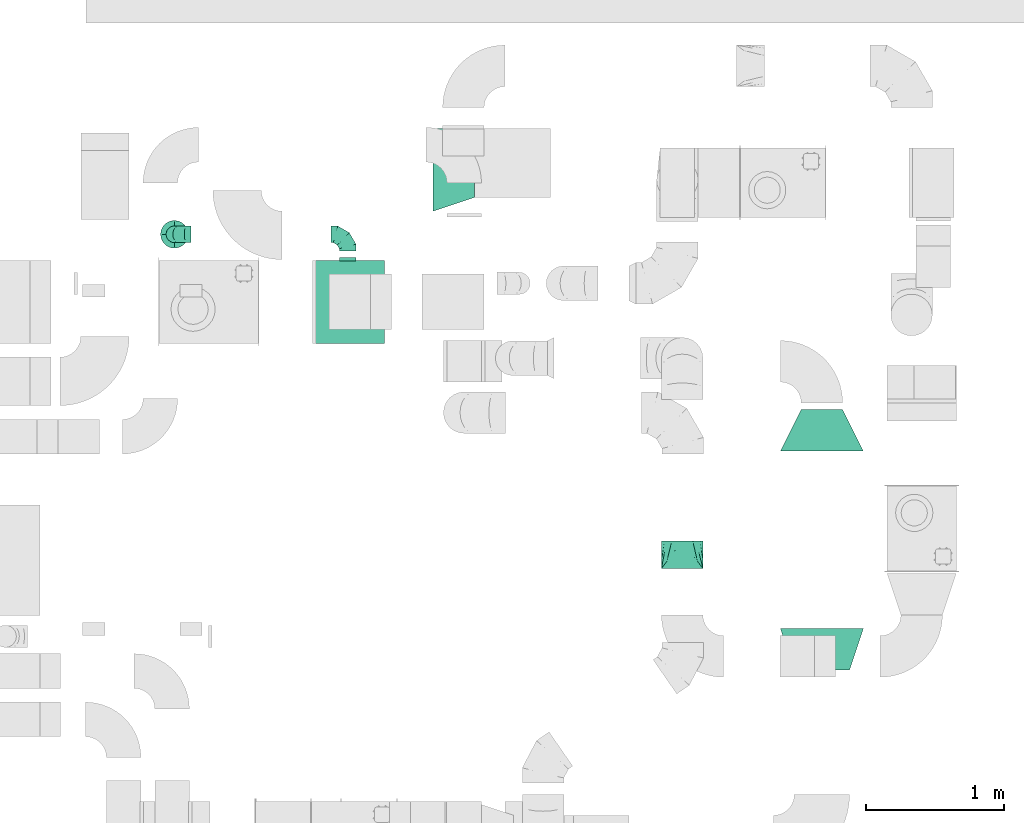
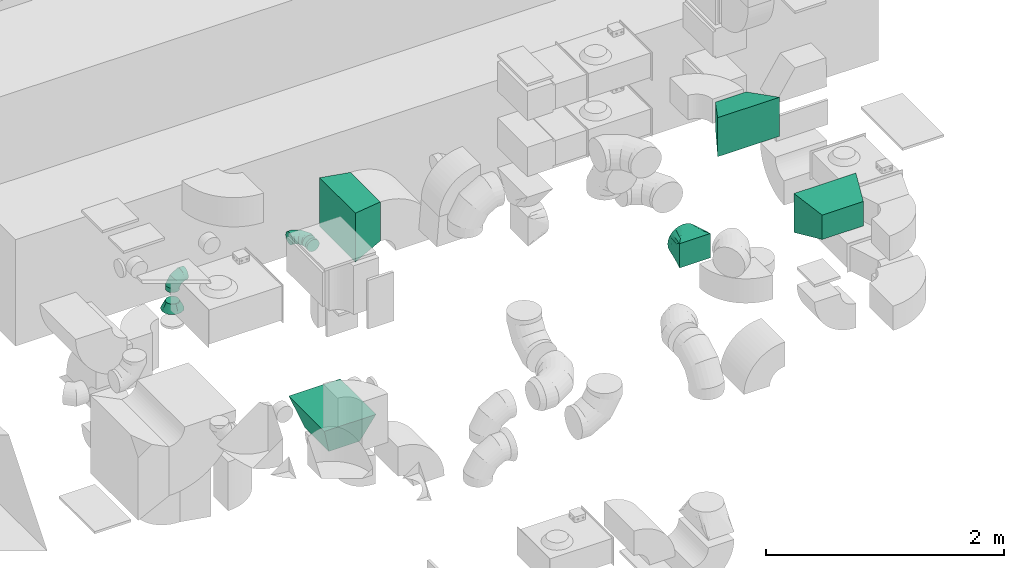
# One storey, part 51 of 59: 9 flow fittings.
"""IFC2X3 building model written with IfcOpenShell, lengths in millimetres."""

from ifc_helpers import new_model, entity, si_unit, converted_unit, derived_unit, direction, frame, origin, place, context, subcontext, project, spatial, faceted_brep, source, transform, mapped, material, type_object, type_shapes, element, save


model = new_model("IFC2X3")

# Units and contexts
model_context = context("Model", 3, precision=0.01, world=origin(), true_north=direction((6.12303176911189e-17, 1.0)))
body_context = subcontext(model_context, "Body", "Model", "MODEL_VIEW")
ifc_project = project(units=[si_unit("LENGTHUNIT", "METRE", prefix="MILLI"), si_unit("AREAUNIT", "SQUARE_METRE"), si_unit("VOLUMEUNIT", "CUBIC_METRE"), converted_unit("PLANEANGLEUNIT", "DEGREE", entity("IfcRatioMeasure", 0.0174532925199433), si_unit("PLANEANGLEUNIT", "RADIAN"), dimensions=[0, 0, 0, 0, 0, 0, 0]), si_unit("MASSUNIT", "GRAM", prefix="KILO"), derived_unit("MASSDENSITYUNIT", [(si_unit("MASSUNIT", "GRAM", prefix="KILO"), 1), (si_unit("LENGTHUNIT", "METRE"), -3)]), derived_unit("MOMENTOFINERTIAUNIT", [(si_unit("LENGTHUNIT", "METRE"), 4)]), si_unit("TIMEUNIT", "SECOND"), si_unit("FREQUENCYUNIT", "HERTZ"), si_unit("THERMODYNAMICTEMPERATUREUNIT", "DEGREE_CELSIUS"), derived_unit("THERMALTRANSMITTANCEUNIT", [(si_unit("MASSUNIT", "GRAM", prefix="KILO"), 1), (si_unit("THERMODYNAMICTEMPERATUREUNIT", "KELVIN"), -1), (si_unit("TIMEUNIT", "SECOND"), -3)]), derived_unit("VOLUMETRICFLOWRATEUNIT", [(si_unit("LENGTHUNIT", "METRE"), 3), (si_unit("TIMEUNIT", "SECOND"), -1)]), derived_unit("MASSFLOWRATEUNIT", [(si_unit("MASSUNIT", "GRAM", prefix="KILO"), 1), (si_unit("TIMEUNIT", "SECOND"), -1)]), derived_unit("ROTATIONALFREQUENCYUNIT", [(si_unit("TIMEUNIT", "SECOND"), -1)]), si_unit("ELECTRICCURRENTUNIT", "AMPERE"), si_unit("ELECTRICVOLTAGEUNIT", "VOLT"), si_unit("POWERUNIT", "WATT"), si_unit("FORCEUNIT", "NEWTON", prefix="KILO"), si_unit("ILLUMINANCEUNIT", "LUX"), si_unit("LUMINOUSFLUXUNIT", "LUMEN"), si_unit("LUMINOUSINTENSITYUNIT", "CANDELA"), derived_unit("USERDEFINED", [(si_unit("MASSUNIT", "GRAM", prefix="KILO"), -1), (si_unit("LENGTHUNIT", "METRE"), -2), (si_unit("TIMEUNIT", "SECOND"), 3), (si_unit("LUMINOUSFLUXUNIT", "LUMEN"), 1)]), derived_unit("LINEARVELOCITYUNIT", [(si_unit("LENGTHUNIT", "METRE"), 1), (si_unit("TIMEUNIT", "SECOND"), -1)]), si_unit("PRESSUREUNIT", "PASCAL"), derived_unit("USERDEFINED", [(si_unit("LENGTHUNIT", "METRE"), -2), (si_unit("MASSUNIT", "GRAM", prefix="KILO"), 1), (si_unit("TIMEUNIT", "SECOND"), -2)]), derived_unit("LINEARFORCEUNIT", [(si_unit("MASSUNIT", "GRAM", prefix="KILO"), 1), (si_unit("LENGTHUNIT", "METRE"), 1), (si_unit("TIMEUNIT", "SECOND"), -2), (si_unit("LENGTHUNIT", "METRE"), -1)]), derived_unit("PLANARFORCEUNIT", [(si_unit("MASSUNIT", "GRAM", prefix="KILO"), 1), (si_unit("LENGTHUNIT", "METRE"), 1), (si_unit("TIMEUNIT", "SECOND"), -2), (si_unit("LENGTHUNIT", "METRE"), -2)])], contexts=[model_context])

# Site, building, storey
site_placement = place(None, origin())
site = spatial("IfcSite", under=ifc_project, at=site_placement, CompositionType="ELEMENT")
building_placement = place(site_placement, origin())
building = spatial("IfcBuilding", under=site, at=building_placement, CompositionType="ELEMENT")
storey_placement = place(building_placement, frame((0.0, 0.0, 28200.0)))
storey = spatial("IfcBuildingStorey", under=building, at=storey_placement, CompositionType="ELEMENT", Elevation=28200.0)

# Flow fittings
ifc_material = material()
duct_fitting_type_1 = type_object("IfcDuctFittingType", PredefinedType="NOTDEFINED", material=ifc_material)
shared_shape_1 = source(origin(), body_context, "Body", "Brep", [
    faceted_brep([(300.0, -150.0, 125.0), (300.0, -150.0, -125.0), (300.0, 150.0, -125.0), (300.0, 150.0, 125.0), (0.0, -300.0, 200.0), (0.0, 300.0, 200.0), (0.0, 300.0, -200.0), (0.0, -300.0, -200.0)], [[[0, 1, 2, 3]], [[4, 5, 6, 7]], [[4, 7, 1, 0]], [[7, 6, 2, 1]], [[6, 5, 3, 2]], [[5, 4, 0, 3]]]),
])
type_shapes(duct_fitting_type_1, [shared_shape_1])
flow_fitting_1_placement = place(storey_placement, frame((33725.03, 10965.73, 3500.0), z_axis=(0.0, 0.0, 1.0), x_axis=(0.0, 1.0, 0.0)))
element("IfcFlowFitting", 1, at=flow_fitting_1_placement, inside=storey, type_object=duct_fitting_type_1, material=ifc_material, context=body_context, shape_type="MappedRepresentation", body=[
    mapped(shared_shape_1, transform((0.0, 0.0, 0.0), scale=1.0)),
])
duct_fitting_type_2 = type_object("IfcDuctFittingType", PredefinedType="NOTDEFINED", material=ifc_material)
shared_shape_2 = source(origin(), body_context, "Body", "Brep", [
    faceted_brep([(200.0, 75.0, 129.9), (200.0, 56.91, 137.4), (200.0, 38.82, 144.89), (200.0, 26.6, 146.5), (200.0, 14.38, 148.11), (200.0, 0.0, 150.0), (200.0, -14.38, 148.11), (200.0, -26.6, 146.5), (200.0, -38.82, 144.89), (200.0, -56.91, 137.4), (200.0, -75.0, 129.9), (200.0, -90.53, 117.98), (200.0, -106.07, 106.07), (200.0, -117.98, 90.53), (200.0, -129.9, 75.0), (200.0, -137.4, 56.91), (200.0, -144.89, 38.82), (200.0, -146.5, 26.6), (200.0, -148.11, 14.38), (200.0, -150.0, 0.0), (200.0, -148.11, -14.38), (200.0, -146.5, -26.6), (200.0, -144.89, -38.82), (200.0, -137.4, -56.91), (200.0, -129.9, -75.0), (200.0, -117.98, -90.53), (200.0, -106.07, -106.07), (200.0, -90.53, -117.98), (200.0, -75.0, -129.9), (200.0, -56.91, -137.4), (200.0, -38.82, -144.89), (200.0, -26.6, -146.5), (200.0, -14.38, -148.11), (200.0, 0.0, -150.0), (200.0, 14.38, -148.11), (200.0, 26.6, -146.5), (200.0, 38.82, -144.89), (200.0, 56.91, -137.4), (200.0, 75.0, -129.9), (200.0, 90.53, -117.98), (200.0, 106.07, -106.07), (200.0, 117.98, -90.53), (200.0, 129.9, -75.0), (200.0, 137.4, -56.91), (200.0, 144.89, -38.82), (200.0, 146.5, -26.6), (200.0, 148.11, -14.38), (200.0, 150.0, 0.0), (200.0, 148.11, 14.38), (200.0, 146.5, 26.6), (200.0, 144.89, 38.82), (200.0, 137.4, 56.91), (200.0, 129.9, 75.0), (200.0, 117.98, 90.53), (200.0, 106.07, 106.07), (200.0, 90.53, 117.98), (0.0, -150.0, 125.0), (0.0, 150.0, 125.0), (0.0, 150.0, -125.0), (0.0, -150.0, -125.0), (128.09, -53.94, 141.01), (104.11, -71.91, 138.01), (78.09, -91.44, 134.76), (100.0, -124.73, 118.65), (26.03, -130.48, 128.25), (52.06, -150.0, 92.46), (26.03, -150.0, 108.73), (78.09, -150.0, 76.2), (104.11, -150.0, 59.93), (128.09, -150.0, 44.95), (176.03, -17.98, 147.0), (152.06, -35.96, 144.01), (152.06, -150.0, 29.96), (176.03, -150.0, 14.98), (52.06, -110.96, 131.51), (26.03, -150.0, -108.73), (52.06, -150.0, -92.46), (78.09, -150.0, -76.2), (104.11, -150.0, -59.93), (128.09, -150.0, -44.95), (152.06, -150.0, -29.96), (176.03, -150.0, -14.98), (100.0, -131.15, -112.23), (52.06, -110.96, -131.51), (26.03, -130.48, -128.25), (78.09, -91.44, -134.76), (104.11, -71.91, -138.01), (128.09, -53.94, -141.01), (152.06, -35.96, -144.01), (176.03, -17.98, -147.0), (26.03, 130.48, -128.25), (52.06, 110.96, -131.51), (78.09, 91.44, -134.76), (104.11, 71.91, -138.01), (128.09, 53.94, -141.01), (152.06, 35.96, -144.01), (176.03, 17.98, -147.0), (100.0, 124.73, -118.65), (52.06, 150.0, -92.46), (26.03, 150.0, -108.73), (78.09, 150.0, -76.2), (104.11, 150.0, -59.93), (128.09, 150.0, -44.95), (152.06, 150.0, -29.96), (176.03, 150.0, -14.98), (26.03, 150.0, 108.73), (52.06, 150.0, 92.46), (78.09, 150.0, 76.2), (104.11, 150.0, 59.93), (128.09, 150.0, 44.95), (152.06, 150.0, 29.96), (176.03, 150.0, 14.98), (100.0, 131.15, 112.23), (52.06, 110.96, 131.51), (26.03, 130.48, 128.25), (78.09, 91.44, 134.76), (104.11, 71.91, 138.01), (128.09, 53.94, 141.01), (152.06, 35.96, 144.01), (176.03, 17.98, 147.0)], [[[0, 1, 2, 3, 4, 5, 6, 7, 8, 9, 10, 11, 12, 13, 14, 15, 16, 17, 18, 19, 20, 21, 22, 23, 24, 25, 26, 27, 28, 29, 30, 31, 32, 33, 34, 35, 36, 37, 38, 39, 40, 41, 42, 43, 44, 45, 46, 47, 48, 49, 50, 51, 52, 53, 54, 55]], [[56, 57, 58, 59]], [[60, 61, 62, 9]], [[63, 11, 64]], [[13, 12, 63]], [[8, 60, 9]], [[9, 62, 10]], [[65, 14, 13]], [[13, 63, 66]], [[15, 67, 68, 69]], [[70, 71, 60, 8, 7, 6, 5]], [[17, 16, 69, 72, 73, 19, 18]], [[15, 14, 67]], [[15, 69, 16]], [[14, 65, 67]], [[11, 74, 64]], [[11, 10, 74]], [[56, 63, 64]], [[11, 63, 12]], [[13, 66, 65]], [[63, 56, 66]], [[62, 74, 10]], [[73, 72, 69, 68, 67, 65, 66, 56, 59, 75, 76, 77, 78, 79, 80, 81, 19]], [[79, 78, 77, 23]], [[82, 25, 75]], [[27, 26, 82]], [[22, 79, 23]], [[23, 77, 24]], [[83, 28, 27]], [[27, 82, 84]], [[29, 85, 86, 87]], [[81, 80, 79, 22, 21, 20, 19]], [[31, 30, 87, 88, 89, 33, 32]], [[29, 28, 85]], [[29, 87, 30]], [[28, 83, 85]], [[25, 76, 75]], [[25, 24, 76]], [[59, 82, 75]], [[25, 82, 26]], [[27, 84, 83]], [[82, 59, 84]], [[77, 76, 24]], [[89, 88, 87, 86, 85, 83, 84, 59, 58, 90, 91, 92, 93, 94, 95, 96, 33]], [[94, 93, 92, 37]], [[97, 39, 90]], [[41, 40, 97]], [[36, 94, 37]], [[37, 92, 38]], [[98, 42, 41]], [[41, 97, 99]], [[43, 100, 101, 102]], [[96, 95, 94, 36, 35, 34, 33]], [[45, 44, 102, 103, 104, 47, 46]], [[43, 42, 100]], [[43, 102, 44]], [[42, 98, 100]], [[39, 91, 90]], [[39, 38, 91]], [[58, 97, 90]], [[39, 97, 40]], [[41, 99, 98]], [[97, 58, 99]], [[92, 91, 38]], [[58, 57, 105, 106, 107, 108, 109, 110, 111, 47, 104, 103, 102, 101, 100, 98, 99]], [[109, 108, 107, 51]], [[112, 53, 105]], [[55, 54, 112]], [[50, 109, 51]], [[51, 107, 52]], [[113, 0, 55]], [[55, 112, 114]], [[1, 115, 116, 117]], [[111, 110, 109, 50, 49, 48, 47]], [[3, 2, 117, 118, 119, 5, 4]], [[1, 0, 115]], [[1, 117, 2]], [[0, 113, 115]], [[53, 106, 105]], [[53, 52, 106]], [[57, 112, 105]], [[53, 112, 54]], [[55, 114, 113]], [[112, 57, 114]], [[107, 106, 52]], [[57, 56, 64, 74, 62, 61, 60, 71, 70, 5, 119, 118, 117, 116, 115, 113, 114]]]),
])
type_shapes(duct_fitting_type_2, [shared_shape_2])
flow_fitting_2_placement = place(storey_placement, frame((32715.69, 10117.62, 3100.0), z_axis=(0.0, 0.0, 1.0), x_axis=(0.0, 1.0, 0.0)))
element("IfcFlowFitting", 2, at=flow_fitting_2_placement, inside=storey, type_object=duct_fitting_type_2, material=ifc_material, context=body_context, shape_type="MappedRepresentation", body=[
    mapped(shared_shape_2, transform((0.0, 0.0, 0.0), scale=1.0)),
])
duct_fitting_type_3 = type_object("IfcDuctFittingType", PredefinedType="NOTDEFINED", material=ifc_material)
shared_shape_3 = source(origin(), body_context, "Body", "Brep", [
    faceted_brep([(300.0, -300.0, 250.0), (300.0, -300.0, -250.0), (300.0, 300.0, -250.0), (300.0, 300.0, 250.0), (0.0, -200.0, 150.0), (0.0, 200.0, 150.0), (0.0, 200.0, -150.0), (0.0, -200.0, -150.0)], [[[0, 1, 2, 3]], [[4, 5, 6, 7]], [[4, 7, 1, 0]], [[7, 6, 2, 1]], [[6, 5, 3, 2]], [[5, 4, 0, 3]]]),
])
type_shapes(duct_fitting_type_3, [shared_shape_3])
flow_fitting_3_placement = place(storey_placement, frame((30315.03, 12045.06, 890.0), z_axis=(-1.0, 0.0, 0.0), x_axis=(0.0, 0.0, 1.0)))
element("IfcFlowFitting", 3, at=flow_fitting_3_placement, inside=storey, type_object=duct_fitting_type_3, material=ifc_material, context=body_context, shape_type="MappedRepresentation", body=[
    mapped(shared_shape_3, transform((0.0, 0.0, 0.0), scale=1.0)),
])
duct_fitting_type_4 = type_object("IfcDuctFittingType", PredefinedType="NOTDEFINED", material=ifc_material)
shared_shape_4 = source(origin(), body_context, "Body", "Brep", [
    faceted_brep([(300.0, -200.0, 200.0), (300.0, -200.0, -200.0), (300.0, 300.0, -200.0), (300.0, 300.0, 200.0), (0.0, -300.0, 250.0), (0.0, 300.0, 250.0), (0.0, 300.0, -250.0), (0.0, -300.0, -250.0)], [[[0, 1, 2, 3]], [[4, 5, 6, 7]], [[4, 7, 1, 0]], [[7, 6, 2, 1]], [[6, 5, 3, 2]], [[5, 4, 0, 3]]]),
])
type_shapes(duct_fitting_type_4, [shared_shape_4])
flow_fitting_4_placement = place(storey_placement, frame((30914.55, 12998.57, 2300.0)))
element("IfcFlowFitting", 4, at=flow_fitting_4_placement, inside=storey, type_object=duct_fitting_type_4, material=ifc_material, context=body_context, shape_type="MappedRepresentation", body=[
    mapped(shared_shape_4, transform((0.0, 0.0, 0.0), scale=1.0)),
])
duct_fitting_type_5 = type_object("IfcDuctFittingType", PredefinedType="NOTDEFINED", material=ifc_material)
shared_shape_5 = source(origin(), body_context, "Body", "Brep", [
    faceted_brep([(20.0, 15.53, -57.96), (20.0, 30.0, -51.96), (20.0, 42.43, -42.43), (20.0, 51.96, -30.0), (20.0, 57.96, -15.53), (20.0, 60.0, 0.0), (20.0, 57.96, 15.53), (20.0, 51.96, 30.0), (20.0, 42.43, 42.43), (20.0, 30.0, 51.96), (20.0, 15.53, 57.96), (20.0, 0.0, 60.0), (20.0, -15.53, 57.96), (20.0, -30.0, 51.96), (20.0, -42.43, 42.43), (20.0, -51.96, 30.0), (20.0, -57.96, 15.53), (20.0, -60.0, 0.0), (20.0, -57.96, -15.53), (20.0, -51.96, -30.0), (20.0, -42.43, -42.43), (20.0, -30.0, -51.96), (20.0, -15.53, -57.96), (20.0, 0.0, -60.0), (0.0, 0.0, 60.0), (0.0, 15.53, 57.96), (-6.1, 15.53, 57.96), (-6.1, 0.0, 60.0), (0.0, 30.0, 51.96), (-6.1, 30.0, 51.96), (0.0, 42.43, 42.43), (-6.1, 42.43, 42.43), (0.0, 51.96, 30.0), (0.0, 57.96, 15.53), (-6.1, 57.96, 15.53), (-6.1, 51.96, 30.0), (0.0, 60.0, 0.0), (-6.1, 60.0, 0.0), (0.0, 57.96, -15.53), (-6.1, 57.96, -15.53), (0.0, 51.96, -30.0), (-6.1, 51.96, -30.0), (0.0, 42.43, -42.43), (-6.1, 42.43, -42.43), (0.0, 30.0, -51.96), (0.0, 15.53, -57.96), (-6.1, 15.53, -57.96), (-6.1, 30.0, -51.96), (0.0, 0.0, -60.0), (-6.1, 0.0, -60.0), (0.0, -15.53, -57.96), (-6.1, -15.53, -57.96), (0.0, -30.0, -51.96), (-6.1, -30.0, -51.96), (0.0, -42.43, -42.43), (-6.1, -42.43, -42.43), (0.0, -51.96, -30.0), (0.0, -57.96, -15.53), (-6.1, -57.96, -15.53), (-6.1, -51.96, -30.0), (0.0, -60.0, 0.0), (-6.1, -60.0, 0.0), (0.0, -57.96, 15.53), (-6.1, -57.96, 15.53), (0.0, -51.96, 30.0), (-6.1, -51.96, 30.0), (0.0, -42.43, 42.43), (-6.1, -42.43, 42.43), (0.0, -30.0, 51.96), (0.0, -15.53, 57.96), (-6.1, -15.53, 57.96), (-6.1, -30.0, 51.96)], [[[0, 1, 2, 3, 4, 5, 6, 7, 8, 9, 10, 11, 12, 13, 14, 15, 16, 17, 18, 19, 20, 21, 22, 23]], [[24, 11, 10, 25, 26, 27]], [[25, 10, 9, 28, 29, 26]], [[28, 9, 8, 30, 31, 29]], [[32, 7, 6, 33, 34, 35]], [[33, 6, 5, 36, 37, 34]], [[30, 8, 7, 32, 35, 31]], [[36, 5, 4, 38, 39, 37]], [[38, 4, 3, 40, 41, 39]], [[40, 3, 2, 42, 43, 41]], [[44, 1, 0, 45, 46, 47]], [[45, 0, 23, 48, 49, 46]], [[42, 2, 1, 44, 47, 43]], [[48, 23, 22, 50, 51, 49]], [[50, 22, 21, 52, 53, 51]], [[52, 21, 20, 54, 55, 53]], [[56, 19, 18, 57, 58, 59]], [[57, 18, 17, 60, 61, 58]], [[54, 20, 19, 56, 59, 55]], [[60, 17, 16, 62, 63, 61]], [[62, 16, 15, 64, 65, 63]], [[64, 15, 14, 66, 67, 65]], [[68, 13, 12, 69, 70, 71]], [[69, 12, 11, 24, 27, 70]], [[66, 14, 13, 68, 71, 67]], [[49, 51, 53, 55, 59, 58, 61, 63, 65, 67, 71, 70, 27, 26, 29, 31, 35, 34, 37, 39, 41, 43, 47, 46]]]),
])
type_shapes(duct_fitting_type_5, [shared_shape_5])
flow_fitting_5_placement = place(storey_placement, frame((30298.6, 12345.06, 2652.08), z_axis=(1.0, 0.0, 0.0), x_axis=(0.0, 1.0, 0.0)))
element("IfcFlowFitting", 5, at=flow_fitting_5_placement, inside=storey, type_object=duct_fitting_type_5, material=ifc_material, context=body_context, shape_type="MappedRepresentation", body=[
    mapped(shared_shape_5, transform((0.0, 0.0, 0.0), scale=1.0)),
])
duct_fitting_type_6 = type_object("IfcDuctFittingType", PredefinedType="NOTDEFINED", material=ifc_material)
shared_shape_6 = source(origin(), body_context, "Body", "Brep", [
    faceted_brep([(-120.0, 0.0, -60.0), (-120.0, -15.53, -57.96), (-120.0, -30.0, -51.96), (-120.0, -42.43, -42.43), (-120.0, -51.96, -30.0), (-120.0, -57.96, -15.53), (-120.0, -60.0, 0.0), (-120.0, -57.96, 15.53), (-120.0, -51.96, 30.0), (-120.0, -42.43, 42.43), (-120.0, -30.0, 51.96), (-120.0, -15.53, 57.96), (-120.0, 0.0, 60.0), (-120.0, 15.53, 57.96), (-120.0, 30.0, 51.96), (-120.0, 42.43, 42.43), (-120.0, 51.96, 30.0), (-120.0, 57.96, 15.53), (-120.0, 60.0, 0.0), (-120.0, 57.96, -15.53), (-120.0, 51.96, -30.0), (-120.0, 42.43, -42.43), (-120.0, 30.0, -51.96), (-120.0, 15.53, -57.96), (-92.01, 15.53, 57.96), (-95.88, 30.0, 51.96), (-87.85, 0.0, 60.0), (-99.21, 42.43, 42.43), (-103.38, 57.96, 15.53), (-103.92, 60.0, 0.0), (-101.77, 51.96, 30.0), (-101.77, 51.96, -30.0), (-99.21, 42.43, -42.43), (-103.38, 57.96, -15.53), (-92.01, 15.53, -57.96), (-87.85, 0.0, -60.0), (-95.88, 30.0, -51.96), (-83.69, -15.53, -57.96), (-79.81, -30.0, -51.96), (-76.48, -42.43, -42.43), (-73.92, -51.96, -30.0), (-72.32, -57.96, -15.53), (-71.77, -60.0, 0.0), (-72.32, -57.96, 15.53), (-73.92, -51.96, 30.0), (-76.48, -42.43, 42.43), (-79.81, -30.0, 51.96), (-83.69, -15.53, 57.96), (-43.52, 43.52, 57.96), (-54.12, 54.12, 51.96), (-32.15, 32.15, 60.0), (-63.21, 63.21, 42.43), (-70.19, 70.19, 30.0), (-74.58, 74.58, 15.53), (-76.08, 76.08, 0.0), (-74.58, 74.58, -15.53), (-70.19, 70.19, -30.0), (-63.21, 63.21, -42.43), (-43.52, 43.52, -57.96), (-32.15, 32.15, -60.0), (-54.12, 54.12, -51.96), (-20.79, 20.79, -57.96), (-10.19, 10.19, -51.96), (-1.1, 1.1, -42.43), (5.88, -5.88, -30.0), (10.27, -10.27, -15.53), (11.77, -11.77, 0.0), (10.27, -10.27, 15.53), (5.88, -5.88, 30.0), (-1.1, 1.1, 42.43), (-10.19, 10.19, 51.96), (-20.79, 20.79, 57.96), (-15.53, 92.01, 57.96), (-30.0, 95.88, 51.96), (0.0, 87.85, 60.0), (-42.43, 99.21, 42.43), (-51.96, 101.77, 30.0), (-57.96, 103.38, 15.53), (-60.0, 103.92, 0.0), (-57.96, 103.38, -15.53), (-51.96, 101.77, -30.0), (-42.43, 99.21, -42.43), (-15.53, 92.01, -57.96), (0.0, 87.85, -60.0), (-30.0, 95.88, -51.96), (15.53, 83.69, -57.96), (30.0, 79.81, -51.96), (42.43, 76.48, -42.43), (51.96, 73.92, -30.0), (57.96, 72.32, -15.53), (60.0, 71.77, 0.0), (57.96, 72.32, 15.53), (51.96, 73.92, 30.0), (42.43, 76.48, 42.43), (30.0, 79.81, 51.96), (15.53, 83.69, 57.96), (-15.53, 120.0, -57.96), (-30.0, 120.0, -51.96), (-42.43, 120.0, -42.43), (-51.96, 120.0, -30.0), (-57.96, 120.0, -15.53), (-60.0, 120.0, 0.0), (-57.96, 120.0, 15.53), (-51.96, 120.0, 30.0), (-42.43, 120.0, 42.43), (-30.0, 120.0, 51.96), (-15.53, 120.0, 57.96), (0.0, 120.0, 60.0), (15.53, 120.0, 57.96), (30.0, 120.0, 51.96), (42.43, 120.0, 42.43), (51.96, 120.0, 30.0), (57.96, 120.0, 15.53), (60.0, 120.0, 0.0), (57.96, 120.0, -15.53), (51.96, 120.0, -30.0), (42.43, 120.0, -42.43), (30.0, 120.0, -51.96), (15.53, 120.0, -57.96), (0.0, 120.0, -60.0)], [[[0, 1, 2, 3, 4, 5, 6, 7, 8, 9, 10, 11, 12, 13, 14, 15, 16, 17, 18, 19, 20, 21, 22, 23]], [[24, 25, 14, 13]], [[26, 24, 13, 12]], [[14, 25, 27, 15]], [[28, 29, 18, 17]], [[30, 28, 17, 16]], [[15, 27, 30, 16]], [[20, 31, 32, 21]], [[33, 31, 20, 19]], [[18, 29, 33, 19]], [[34, 35, 0, 23]], [[36, 34, 23, 22]], [[21, 32, 36, 22]], [[1, 0, 35, 37]], [[2, 1, 37, 38]], [[3, 2, 38, 39]], [[5, 4, 40, 41]], [[6, 5, 41, 42]], [[39, 40, 4, 3]], [[6, 42, 43, 7]], [[7, 43, 44, 8]], [[8, 44, 45, 9]], [[9, 45, 46, 10]], [[10, 46, 47, 11]], [[26, 12, 11, 47]], [[48, 49, 25, 24]], [[50, 48, 24, 26]], [[27, 25, 49, 51]], [[52, 53, 28, 30]], [[51, 52, 30, 27]], [[29, 28, 53, 54]], [[55, 56, 31, 33]], [[54, 55, 33, 29]], [[57, 32, 31, 56]], [[58, 59, 35, 34]], [[60, 58, 34, 36]], [[57, 60, 36, 32]], [[37, 35, 59, 61]], [[38, 37, 61, 62]], [[39, 38, 62, 63]], [[41, 40, 64, 65]], [[42, 41, 65, 66]], [[63, 64, 40, 39]], [[43, 42, 66, 67]], [[44, 43, 67, 68]], [[68, 69, 45, 44]], [[46, 45, 69, 70]], [[47, 46, 70, 71]], [[26, 47, 71, 50]], [[72, 73, 49, 48]], [[74, 72, 48, 50]], [[51, 49, 73, 75]], [[76, 77, 53, 52]], [[75, 76, 52, 51]], [[54, 53, 77, 78]], [[79, 80, 56, 55]], [[78, 79, 55, 54]], [[81, 57, 56, 80]], [[82, 83, 59, 58]], [[84, 82, 58, 60]], [[81, 84, 60, 57]], [[61, 59, 83, 85]], [[62, 61, 85, 86]], [[63, 62, 86, 87]], [[65, 64, 88, 89]], [[66, 65, 89, 90]], [[87, 88, 64, 63]], [[67, 66, 90, 91]], [[68, 67, 91, 92]], [[92, 93, 69, 68]], [[70, 69, 93, 94]], [[71, 70, 94, 95]], [[50, 71, 95, 74]], [[96, 97, 98, 99, 100, 101, 102, 103, 104, 105, 106, 107, 108, 109, 110, 111, 112, 113, 114, 115, 116, 117, 118, 119]], [[72, 74, 107, 106]], [[73, 72, 106, 105]], [[75, 73, 105, 104]], [[77, 76, 103, 102]], [[78, 77, 102, 101]], [[75, 104, 103, 76]], [[78, 101, 100, 79]], [[79, 100, 99, 80]], [[80, 99, 98, 81]], [[96, 119, 83, 82]], [[97, 96, 82, 84]], [[84, 81, 98, 97]], [[83, 119, 118, 85]], [[85, 118, 117, 86]], [[116, 87, 86, 117]], [[88, 115, 114, 89]], [[89, 114, 113, 90]], [[115, 88, 87, 116]], [[91, 90, 113, 112]], [[92, 91, 112, 111]], [[111, 110, 93, 92]], [[95, 94, 109, 108]], [[74, 95, 108, 107]], [[110, 109, 94, 93]]]),
])
type_shapes(duct_fitting_type_6, [shared_shape_6])
flow_fitting_6_placement = place(storey_placement, frame((30298.6, 12532.56, 2652.08), z_axis=(-5.98839296290642e-06, 0.0, 1.0), x_axis=(0.0, 1.0, 0.0)))
element("IfcFlowFitting", 6, at=flow_fitting_6_placement, inside=storey, type_object=duct_fitting_type_6, material=ifc_material, context=body_context, shape_type="MappedRepresentation", body=[
    mapped(shared_shape_6, transform((0.0, 0.0, 0.0), scale=1.0)),
])
duct_fitting_type_7 = type_object("IfcDuctFittingType", PredefinedType="NOTDEFINED", material=ifc_material)
shared_shape_7 = source(origin(), body_context, "Body", "Brep", [
    faceted_brep([(-120.0, 0.0, -60.0), (-120.0, -15.53, -57.96), (-120.0, -30.0, -51.96), (-120.0, -42.43, -42.43), (-120.0, -51.96, -30.0), (-120.0, -57.96, -15.53), (-120.0, -60.0, 0.0), (-120.0, -57.96, 15.53), (-120.0, -51.96, 30.0), (-120.0, -42.43, 42.43), (-120.0, -30.0, 51.96), (-120.0, -15.53, 57.96), (-120.0, 0.0, 60.0), (-120.0, 15.53, 57.96), (-120.0, 30.0, 51.96), (-120.0, 42.43, 42.43), (-120.0, 51.96, 30.0), (-120.0, 57.96, 15.53), (-120.0, 60.0, 0.0), (-120.0, 57.96, -15.53), (-120.0, 51.96, -30.0), (-120.0, 42.43, -42.43), (-120.0, 30.0, -51.96), (-120.0, 15.53, -57.96), (-92.01, 15.53, 57.96), (-95.88, 30.0, 51.96), (-87.85, 0.0, 60.0), (-99.21, 42.43, 42.43), (-103.37, 57.96, 15.53), (-103.92, 60.0, 0.0), (-101.77, 51.96, 30.0), (-101.77, 51.96, -30.0), (-99.21, 42.43, -42.43), (-103.37, 57.96, -15.53), (-92.01, 15.53, -57.96), (-87.85, 0.0, -60.0), (-95.88, 30.0, -51.96), (-83.68, -15.53, -57.96), (-79.81, -30.0, -51.96), (-76.48, -42.43, -42.43), (-73.92, -51.96, -30.0), (-72.32, -57.96, -15.53), (-71.77, -60.0, 0.0), (-72.32, -57.96, 15.53), (-73.92, -51.96, 30.0), (-76.48, -42.43, 42.43), (-79.81, -30.0, 51.96), (-83.68, -15.53, 57.96), (-43.52, 43.52, 57.96), (-54.11, 54.12, 51.96), (-32.15, 32.15, 60.0), (-63.21, 63.21, 42.43), (-70.19, 70.19, 30.0), (-74.58, 74.58, 15.53), (-76.08, 76.08, 0.0), (-74.58, 74.58, -15.53), (-70.19, 70.19, -30.0), (-63.21, 63.21, -42.43), (-43.52, 43.52, -57.96), (-32.15, 32.15, -60.0), (-54.11, 54.12, -51.96), (-20.79, 20.79, -57.96), (-10.19, 10.19, -51.96), (-1.1, 1.1, -42.43), (5.88, -5.88, -30.0), (10.27, -10.27, -15.53), (11.77, -11.77, 0.0), (10.27, -10.27, 15.53), (5.88, -5.88, 30.0), (-1.1, 1.1, 42.43), (-10.19, 10.19, 51.96), (-20.79, 20.79, 57.96), (-15.53, 92.01, 57.96), (-30.0, 95.88, 51.96), (0.0, 87.85, 60.0), (-42.43, 99.21, 42.43), (-51.96, 101.77, 30.0), (-57.95, 103.37, 15.53), (-60.0, 103.92, 0.0), (-57.95, 103.37, -15.53), (-51.96, 101.77, -30.0), (-42.43, 99.21, -42.43), (-15.53, 92.01, -57.96), (0.0, 87.85, -60.0), (-30.0, 95.88, -51.96), (15.53, 83.68, -57.96), (30.0, 79.81, -51.96), (42.43, 76.48, -42.43), (51.96, 73.92, -30.0), (57.96, 72.32, -15.53), (60.0, 71.77, 0.0), (57.96, 72.32, 15.53), (51.96, 73.92, 30.0), (42.43, 76.48, 42.43), (30.0, 79.81, 51.96), (15.53, 83.68, 57.96), (-60.0, 120.0, 0.0), (-57.95, 120.0, 15.53), (-51.96, 120.0, 30.0), (-42.43, 120.0, 42.43), (-30.0, 120.0, 51.96), (-15.53, 120.0, 57.96), (0.0, 120.0, 60.0), (15.53, 120.0, 57.96), (30.0, 120.0, 51.96), (42.43, 120.0, 42.43), (51.96, 120.0, 30.0), (57.96, 120.0, 15.53), (60.0, 120.0, 0.0), (57.96, 120.0, -15.53), (51.96, 120.0, -30.0), (42.43, 120.0, -42.43), (30.0, 120.0, -51.96), (15.53, 120.0, -57.96), (0.0, 120.0, -60.0), (-15.53, 120.0, -57.96), (-30.0, 120.0, -51.96), (-42.43, 120.0, -42.43), (-51.96, 120.0, -30.0), (-57.95, 120.0, -15.53)], [[[0, 1, 2, 3, 4, 5, 6, 7, 8, 9, 10, 11, 12, 13, 14, 15, 16, 17, 18, 19, 20, 21, 22, 23]], [[24, 25, 14, 13]], [[26, 24, 13, 12]], [[14, 25, 27, 15]], [[28, 29, 18, 17]], [[30, 28, 17, 16]], [[15, 27, 30, 16]], [[20, 31, 32, 21]], [[33, 31, 20, 19]], [[18, 29, 33, 19]], [[34, 35, 0, 23]], [[36, 34, 23, 22]], [[21, 32, 36, 22]], [[1, 0, 35, 37]], [[2, 1, 37, 38]], [[3, 2, 38, 39]], [[5, 4, 40, 41]], [[6, 5, 41, 42]], [[39, 40, 4, 3]], [[6, 42, 43, 7]], [[7, 43, 44, 8]], [[8, 44, 45, 9]], [[9, 45, 46, 10]], [[10, 46, 47, 11]], [[26, 12, 11, 47]], [[48, 49, 25, 24]], [[50, 48, 24, 26]], [[27, 25, 49, 51]], [[52, 53, 28, 30]], [[51, 52, 30, 27]], [[29, 28, 53, 54]], [[55, 56, 31, 33]], [[54, 55, 33, 29]], [[57, 32, 31, 56]], [[58, 59, 35, 34]], [[60, 58, 34, 36]], [[57, 60, 36, 32]], [[37, 35, 59, 61]], [[38, 37, 61, 62]], [[39, 38, 62, 63]], [[41, 40, 64, 65]], [[42, 41, 65, 66]], [[63, 64, 40, 39]], [[43, 42, 66, 67]], [[44, 43, 67, 68]], [[68, 69, 45, 44]], [[46, 45, 69, 70]], [[47, 46, 70, 71]], [[26, 47, 71, 50]], [[72, 73, 49, 48]], [[74, 72, 48, 50]], [[51, 49, 73, 75]], [[76, 77, 53, 52]], [[75, 76, 52, 51]], [[54, 53, 77, 78]], [[79, 80, 56, 55]], [[78, 79, 55, 54]], [[81, 57, 56, 80]], [[82, 83, 59, 58]], [[84, 82, 58, 60]], [[81, 84, 60, 57]], [[61, 59, 83, 85]], [[62, 61, 85, 86]], [[63, 62, 86, 87]], [[65, 64, 88, 89]], [[66, 65, 89, 90]], [[87, 88, 64, 63]], [[67, 66, 90, 91]], [[68, 67, 91, 92]], [[92, 93, 69, 68]], [[70, 69, 93, 94]], [[71, 70, 94, 95]], [[50, 71, 95, 74]], [[96, 97, 98, 99, 100, 101, 102, 103, 104, 105, 106, 107, 108, 109, 110, 111, 112, 113, 114, 115, 116, 117, 118, 119]], [[72, 74, 102, 101]], [[73, 72, 101, 100]], [[75, 73, 100, 99]], [[77, 76, 98, 97]], [[78, 77, 97, 96]], [[75, 99, 98, 76]], [[78, 96, 119, 79]], [[79, 119, 118, 80]], [[80, 118, 117, 81]], [[115, 114, 83, 82]], [[116, 115, 82, 84]], [[84, 81, 117, 116]], [[83, 114, 113, 85]], [[85, 113, 112, 86]], [[111, 87, 86, 112]], [[88, 110, 109, 89]], [[89, 109, 108, 90]], [[110, 88, 87, 111]], [[91, 90, 108, 107]], [[92, 91, 107, 106]], [[106, 105, 93, 92]], [[95, 94, 104, 103]], [[74, 95, 103, 102]], [[105, 104, 94, 93]]]),
])
type_shapes(duct_fitting_type_7, [shared_shape_7])
flow_fitting_7_placement = place(storey_placement, frame((29046.64, 12532.56, 2652.07), z_axis=(0.0, 1.0, 0.0), x_axis=(0.0, 0.0, 1.0)))
element("IfcFlowFitting", 7, at=flow_fitting_7_placement, inside=storey, type_object=duct_fitting_type_7, material=ifc_material, context=body_context, shape_type="MappedRepresentation", body=[
    mapped(shared_shape_7, transform((0.0, 0.0, 0.0), scale=1.0)),
])
duct_fitting_type_8 = type_object("IfcDuctFittingType", PredefinedType="NOTDEFINED", material=ifc_material)
shared_shape_8 = source(origin(), body_context, "Body", "Brep", [
    faceted_brep([(80.0, -58.78, -80.9), (80.0, -30.9, -95.11), (80.0, 0.0, -100.0), (80.0, 30.9, -95.11), (80.0, 58.78, -80.9), (80.0, 80.9, -58.78), (80.0, 95.11, -30.9), (80.0, 100.0, 0.0), (80.0, 95.11, 30.9), (80.0, 80.9, 58.78), (80.0, 58.78, 80.9), (80.0, 30.9, 95.11), (80.0, 0.0, 100.0), (80.0, -30.9, 95.11), (80.0, -58.78, 80.9), (80.0, -80.9, 58.78), (80.0, -95.11, 30.9), (80.0, -100.0, 0.0), (80.0, -95.11, -30.9), (80.0, -80.9, -58.78), (0.0, -22.96, -55.43), (0.0, -32.69, -48.93), (0.0, -42.43, -42.43), (0.0, -48.93, -32.69), (0.0, -55.43, -22.96), (0.0, -57.72, -11.48), (0.0, -60.0, 0.0), (0.0, -57.72, 11.48), (0.0, -55.43, 22.96), (0.0, -48.93, 32.69), (0.0, -42.43, 42.43), (0.0, -32.69, 48.93), (0.0, -22.96, 55.43), (0.0, -11.48, 57.72), (0.0, 0.0, 60.0), (0.0, 11.48, 57.72), (0.0, 22.96, 55.43), (0.0, 32.69, 48.93), (0.0, 42.43, 42.43), (0.0, 48.93, 32.69), (0.0, 55.43, 22.96), (0.0, 57.72, 11.48), (0.0, 60.0, 0.0), (0.0, 57.72, -11.48), (0.0, 55.43, -22.96), (0.0, 48.93, -32.69), (0.0, 42.43, -42.43), (0.0, 32.69, -48.93), (0.0, 22.96, -55.43), (0.0, 11.48, -57.72), (0.0, 0.0, -60.0), (0.0, -11.48, -57.72)], [[[0, 1, 2, 3, 4, 5, 6, 7, 8, 9, 10, 11, 12, 13, 14, 15, 16, 17, 18, 19]], [[20, 21, 22, 23, 24, 25, 26, 27, 28, 29, 30, 31, 32, 33, 34, 35, 36, 37, 38, 39, 40, 41, 42, 43, 44, 45, 46, 47, 48, 49, 50, 51]], [[7, 41, 8]], [[41, 40, 8]], [[40, 9, 8]], [[11, 36, 35]], [[41, 7, 42]], [[9, 40, 39, 38]], [[10, 38, 37, 36]], [[12, 35, 34]], [[11, 10, 36]], [[12, 11, 35]], [[38, 10, 9]], [[12, 33, 13]], [[33, 32, 13]], [[32, 14, 13]], [[16, 28, 27]], [[33, 12, 34]], [[14, 32, 31, 30]], [[15, 30, 29, 28]], [[17, 27, 26]], [[16, 15, 28]], [[17, 16, 27]], [[30, 15, 14]], [[17, 25, 18]], [[25, 24, 18]], [[24, 19, 18]], [[1, 20, 51]], [[25, 17, 26]], [[19, 24, 23, 22]], [[0, 22, 21, 20]], [[2, 51, 50]], [[1, 0, 20]], [[2, 1, 51]], [[22, 0, 19]], [[2, 49, 3]], [[49, 48, 3]], [[48, 4, 3]], [[6, 44, 43]], [[49, 2, 50]], [[4, 48, 47, 46]], [[5, 46, 45, 44]], [[7, 43, 42]], [[6, 5, 44]], [[7, 6, 43]], [[46, 5, 4]]]),
])
type_shapes(duct_fitting_type_8, [shared_shape_8])
flow_fitting_8_placement = place(storey_placement, frame((29046.64, 12532.56, 2414.18), z_axis=(-1.0, 0.0, 0.0), x_axis=(0.0, 0.0, -1.0)))
element("IfcFlowFitting", 8, at=flow_fitting_8_placement, inside=storey, type_object=duct_fitting_type_8, material=ifc_material, context=body_context, shape_type="MappedRepresentation", body=[
    mapped(shared_shape_8, transform((0.0, 0.0, 0.0), scale=1.0)),
])
duct_fitting_type_9 = type_object("IfcDuctFittingType", PredefinedType="NOTDEFINED", material=ifc_material)
shared_shape_9 = source(origin(), body_context, "Body", "Brep", [
    faceted_brep([(300.0, -300.0, 200.0), (300.0, -300.0, -200.0), (300.0, 300.0, -200.0), (300.0, 300.0, 200.0), (0.0, -200.0, 125.0), (0.0, 200.0, 125.0), (0.0, 200.0, -125.0), (0.0, -200.0, -125.0)], [[[0, 1, 2, 3]], [[4, 5, 6, 7]], [[4, 7, 1, 0]], [[7, 6, 2, 1]], [[6, 5, 3, 2]], [[5, 4, 0, 3]]]),
])
type_shapes(duct_fitting_type_9, [shared_shape_9])
flow_fitting_9_placement = place(storey_placement, frame((33725.03, 9385.73, 3500.0), z_axis=(0.0, -3.34141839518175e-08, 1.0), x_axis=(0.0, 1.0, 3.34141839518175e-08)))
element("IfcFlowFitting", 9, at=flow_fitting_9_placement, inside=storey, type_object=duct_fitting_type_9, material=ifc_material, context=body_context, shape_type="MappedRepresentation", body=[
    mapped(shared_shape_9, transform((0.0, 0.0, 0.0), scale=1.0)),
])

save(model, "model.ifc")
